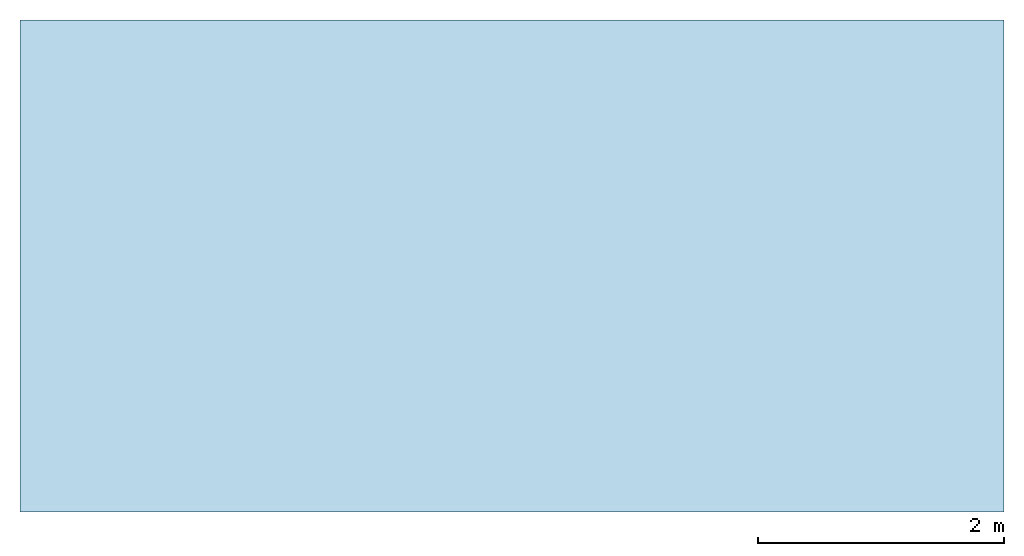
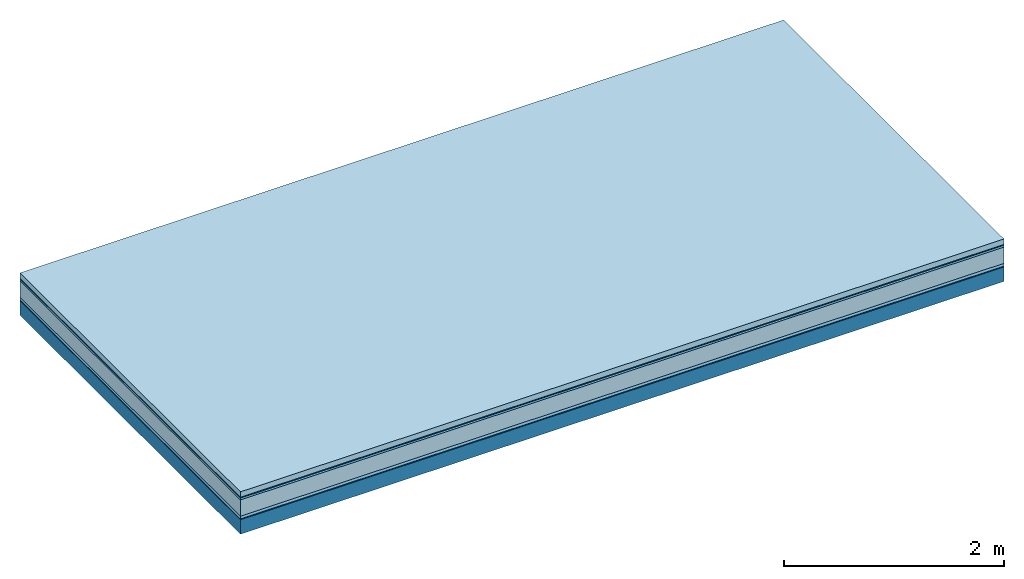
# One storey: 6 plates, 1 member, 1 element without a shape of its own.
"""IFC4 building model written with IfcOpenShell, lengths in metres."""

from ifc_helpers import new_model, si_unit, derived_unit, direction, frame, frame_2d, origin, origin_with_axes, place, context, project, spatial, rectangle, extrude, material, layer, layer_set, type_object, element, aggregate, save


model = new_model("IFC4")

# Units and contexts
plan_context = context("Plan", 3, precision=1e-05, world=origin(), true_north=direction((0.0, 1.0)))
model_context = context("Model", 3, precision=1e-05, world=origin(), true_north=direction((0.0, 1.0)))
ifc_project = project(units=[si_unit("LENGTHUNIT", "METRE"), derived_unit("SOUNDPRESSUREUNIT", [(si_unit("PRESSUREUNIT", "PASCAL", prefix="MICRO"), 0)]), si_unit("ENERGYUNIT", "JOULE", prefix="MEGA"), si_unit("MASSUNIT", "GRAM", prefix="KILO"), derived_unit("THERMALTRANSMITTANCEUNIT", [(si_unit("POWERUNIT", "WATT"), 1), (si_unit("AREAUNIT", "SQUARE_METRE"), -1), (si_unit("THERMODYNAMICTEMPERATUREUNIT", "KELVIN"), -1)]), derived_unit("AREADENSITYUNIT", [(si_unit("MASSUNIT", "GRAM", prefix="KILO"), 1), (si_unit("AREAUNIT", "SQUARE_METRE"), -1)]), derived_unit("USERDEFINED", [(si_unit("ENERGYUNIT", "JOULE", prefix="MEGA"), 1), (si_unit("AREAUNIT", "SQUARE_METRE"), -1)])], contexts=[plan_context, model_context])

# Site, building, storey
site = spatial("IfcSite", under=ifc_project)
building_placement = place(None, origin())
building = spatial("IfcBuilding", under=site, at=building_placement)
storey_placement = place(building_placement, origin())
storey = spatial("IfcBuildingStorey", under=building, at=storey_placement)

# Slab, member, plates
ifc_material_1 = material(Name="clay", Category="02.004")
ifc_layer_1 = layer(ifc_material_1, 0.06, Name="Use and protection layer 2")
ifc_material_2 = material(Name="Protective layer", Category="09.007")
ifc_layer_2 = layer(ifc_material_2, 0.01, Name="Use and protection layer 1")
ifc_material_3 = material(Name="Bituminous", Category="09.003")
ifc_layer_3 = layer(ifc_material_3, 0.02, Name="Seal")
ifc_material_4 = material(Category="10.006")
ifc_layer_4 = layer(ifc_material_4, 0.18, Name="Exterior insulation layer 2")
ifc_material_5 = material(Name="(034) 25 boards", Category="10.004")
ifc_layer_5 = layer(ifc_material_5, 0.03, Name="Exterior insulation layer 1")
ifc_material_6 = material(Name="Vapor-permeable barrier", Category="09.006")
ifc_layer_6 = layer(ifc_material_6, 0.01, Name="layer / temporary roof")
ifc_material_7 = material(Name="no composite action")
ifc_layer_7 = layer(ifc_material_7, 0.0, Name="Bond")
ifc_layer_8 = layer(None, 0.16, Name="Support")
ifc_layer_set = layer_set([ifc_layer_1, ifc_layer_2, ifc_layer_3, ifc_layer_4, ifc_layer_5, ifc_layer_6, ifc_layer_7, ifc_layer_8])
slab_type = type_object("IfcSlabType", Name="F0067", PredefinedType="NOTDEFINED", material=ifc_layer_set)
slab_placement = place(None, frame((0.0, 0.0, 0.0), z_axis=(0.0, 0.0, -1.0), x_axis=(1.0, 0.0, 0.0)))
slab = element("IfcSlab", 1, at=slab_placement, inside=storey, type_object=slab_type, material=ifc_layer_set, Name="Slab #1")
ifc_material_8 = material(Name="Solid timber panel")
member_placement = place(slab_placement, origin())
member = element("IfcMember", 2, at=member_placement, material=ifc_material_8, Name="Support", context=plan_context, shape_type="SweptSolid", body=[
    extrude(rectangle(XDim=1.0, YDim=0.16, at=frame_2d((0.5, 0.08), x_axis=(1.0, 0.0))), frame((0.0, 4.0, 0.31), z_axis=(0.0, -1.0, 0.0), x_axis=(1.0, 0.0, 0.0)), (0.0, 0.0, 1.0), 4.0),
    extrude(rectangle(XDim=1.0, YDim=0.16, at=frame_2d((0.5, 0.08), x_axis=(1.0, 0.0))), frame((1.0, 4.0, 0.31), z_axis=(0.0, -1.0, 0.0), x_axis=(1.0, 0.0, 0.0)), (0.0, 0.0, 1.0), 4.0),
    extrude(rectangle(XDim=1.0, YDim=0.16, at=frame_2d((0.5, 0.08), x_axis=(1.0, 0.0))), frame((2.0, 4.0, 0.31), z_axis=(0.0, -1.0, 0.0), x_axis=(1.0, 0.0, 0.0)), (0.0, 0.0, 1.0), 4.0),
    extrude(rectangle(XDim=1.0, YDim=0.16, at=frame_2d((0.5, 0.08), x_axis=(1.0, 0.0))), frame((3.0, 4.0, 0.31), z_axis=(0.0, -1.0, 0.0), x_axis=(1.0, 0.0, 0.0)), (0.0, 0.0, 1.0), 4.0),
    extrude(rectangle(XDim=1.0, YDim=0.16, at=frame_2d((0.5, 0.08), x_axis=(1.0, 0.0))), frame((4.0, 4.0, 0.31), z_axis=(0.0, -1.0, 0.0), x_axis=(1.0, 0.0, 0.0)), (0.0, 0.0, 1.0), 4.0),
    extrude(rectangle(XDim=1.0, YDim=0.16, at=frame_2d((0.5, 0.08), x_axis=(1.0, 0.0))), frame((5.0, 4.0, 0.31), z_axis=(0.0, -1.0, 0.0), x_axis=(1.0, 0.0, 0.0)), (0.0, 0.0, 1.0), 4.0),
    extrude(rectangle(XDim=1.0, YDim=0.16, at=frame_2d((0.5, 0.08), x_axis=(1.0, 0.0))), frame((6.0, 4.0, 0.31), z_axis=(0.0, -1.0, 0.0), x_axis=(1.0, 0.0, 0.0)), (0.0, 0.0, 1.0), 4.0),
    extrude(rectangle(XDim=1.0, YDim=0.16, at=frame_2d((0.5, 0.08), x_axis=(1.0, 0.0))), frame((7.0, 4.0, 0.31), z_axis=(0.0, -1.0, 0.0), x_axis=(1.0, 0.0, 0.0)), (0.0, 0.0, 1.0), 4.0),
])
plate_1_placement = place(slab_placement, origin())
plate_1 = element("IfcPlate", 3, at=plate_1_placement, material=ifc_material_1, Name="Use and protection layer 2", context=plan_context, shape_type="SweptSolid", body=[
    extrude(rectangle(XDim=8.0, YDim=4.0, at=frame_2d((4.0, 2.0), x_axis=(1.0, 0.0))), origin_with_axes(), (0.0, 0.0, 1.0), 0.06),
])
plate_2_placement = place(slab_placement, origin())
plate_2 = element("IfcPlate", 4, at=plate_2_placement, material=ifc_material_2, Name="Use and protection layer 1", context=plan_context, shape_type="SweptSolid", body=[
    extrude(rectangle(XDim=8.0, YDim=4.0, at=frame_2d((4.0, 2.0), x_axis=(1.0, 0.0))), frame((0.0, 0.0, 0.06), z_axis=(0.0, 0.0, 1.0), x_axis=(1.0, 0.0, 0.0)), (0.0, 0.0, 1.0), 0.01),
])
plate_3_placement = place(slab_placement, origin())
plate_3 = element("IfcPlate", 5, at=plate_3_placement, material=ifc_material_3, Name="Seal", context=plan_context, shape_type="SweptSolid", body=[
    extrude(rectangle(XDim=8.0, YDim=4.0, at=frame_2d((4.0, 2.0), x_axis=(1.0, 0.0))), frame((0.0, 0.0, 0.07), z_axis=(0.0, 0.0, 1.0), x_axis=(1.0, 0.0, 0.0)), (0.0, 0.0, 1.0), 0.02),
])
plate_4_placement = place(slab_placement, origin())
plate_4 = element("IfcPlate", 6, at=plate_4_placement, material=ifc_material_4, Name="Exterior insulation layer 2", context=plan_context, shape_type="SweptSolid", body=[
    extrude(rectangle(XDim=8.0, YDim=4.0, at=frame_2d((4.0, 2.0), x_axis=(1.0, 0.0))), frame((0.0, 0.0, 0.09), z_axis=(0.0, 0.0, 1.0), x_axis=(1.0, 0.0, 0.0)), (0.0, 0.0, 1.0), 0.18),
])
plate_5_placement = place(slab_placement, origin())
plate_5 = element("IfcPlate", 7, at=plate_5_placement, material=ifc_material_5, Name="Exterior insulation layer 1", context=plan_context, shape_type="SweptSolid", body=[
    extrude(rectangle(XDim=8.0, YDim=4.0, at=frame_2d((4.0, 2.0), x_axis=(1.0, 0.0))), frame((0.0, 0.0, 0.27), z_axis=(0.0, 0.0, 1.0), x_axis=(1.0, 0.0, 0.0)), (0.0, 0.0, 1.0), 0.03),
])
plate_6_placement = place(slab_placement, origin())
plate_6 = element("IfcPlate", 8, at=plate_6_placement, material=ifc_material_6, Name="layer / temporary roof", context=plan_context, shape_type="SweptSolid", body=[
    extrude(rectangle(XDim=8.0, YDim=4.0, at=frame_2d((4.0, 2.0), x_axis=(1.0, 0.0))), frame((0.0, 0.0, 0.3), z_axis=(0.0, 0.0, 1.0), x_axis=(1.0, 0.0, 0.0)), (0.0, 0.0, 1.0), 0.01),
])
aggregate(slab, [plate_1, plate_2, plate_3, plate_4, plate_5, plate_6, member])

save(model, "model.ifc")
